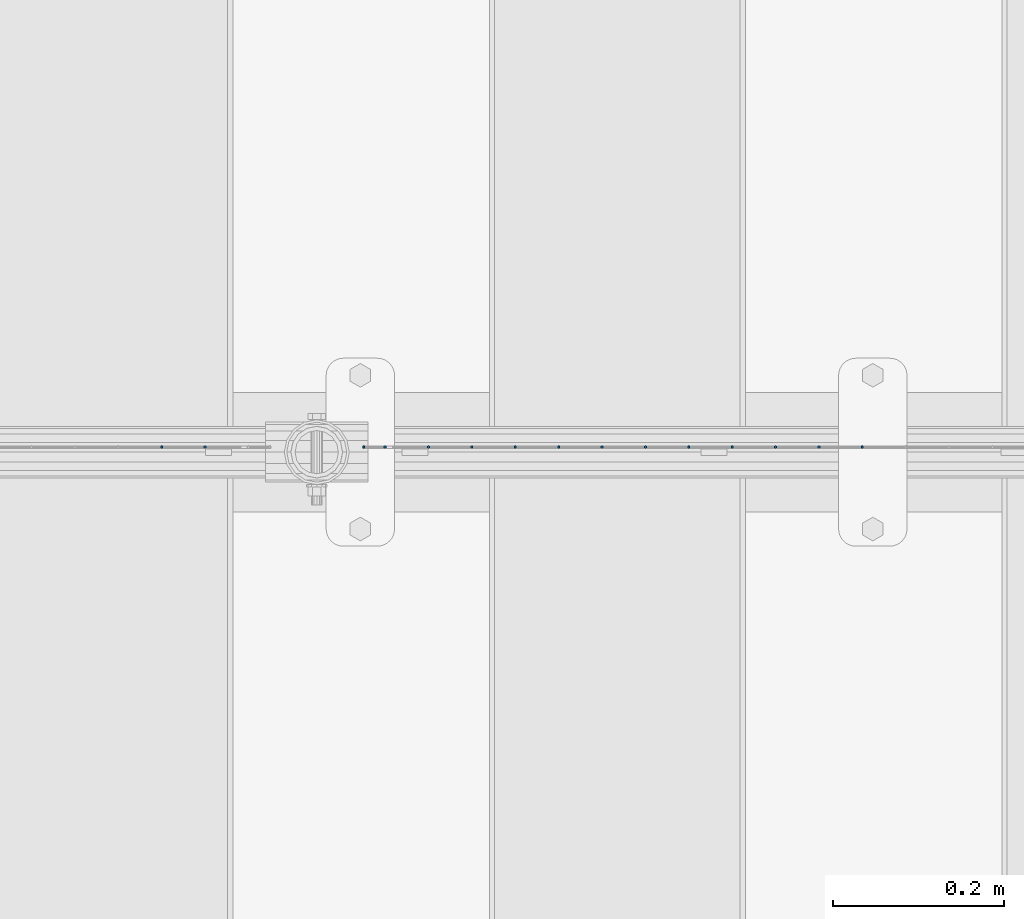
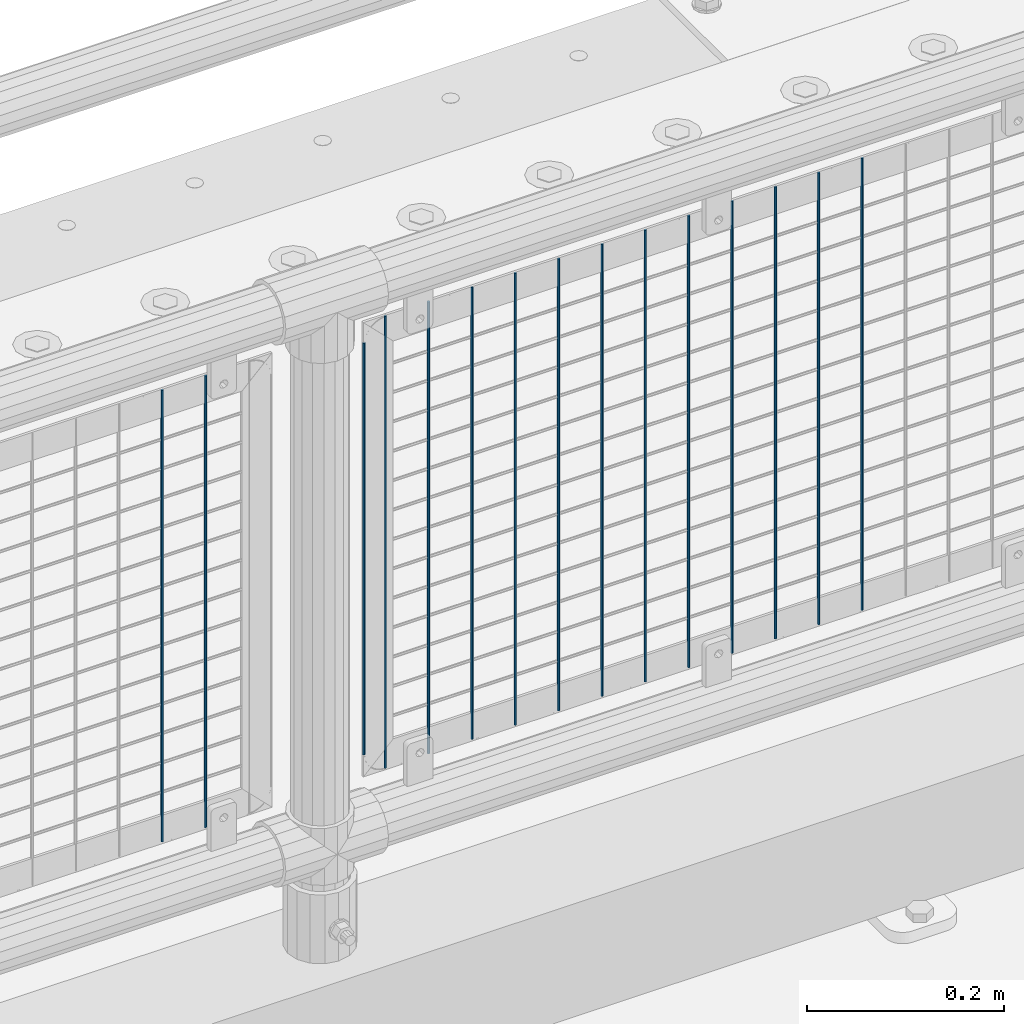
# One storey, part 97 of 242: 15 columns.
"""IFC2X3 building model written with IfcOpenShell, lengths in millimetres."""

from ifc_helpers import new_model, si_unit, frame, origin_with_axes, place, context, subcontext, project, spatial, faceted_brep, material, type_object, element, save


model = new_model("IFC2X3")

# Units and contexts
model_context = context("Model", 3, precision=1e-05, world=origin_with_axes())
body_context = subcontext(model_context, "Body", "Model", "MODEL_VIEW")
ifc_project = project(units=[si_unit("LENGTHUNIT", "METRE", prefix="MILLI"), si_unit("AREAUNIT", "SQUARE_METRE"), si_unit("VOLUMEUNIT", "CUBIC_METRE"), si_unit("MASSUNIT", "GRAM", prefix="KILO"), si_unit("TIMEUNIT", "SECOND"), si_unit("PLANEANGLEUNIT", "RADIAN"), si_unit("SOLIDANGLEUNIT", "STERADIAN"), si_unit("THERMODYNAMICTEMPERATUREUNIT", "DEGREE_CELSIUS"), si_unit("LUMINOUSINTENSITYUNIT", "LUMEN")], contexts=[model_context])

# Site, building, storey
site_placement = place(None, origin_with_axes())
site = spatial("IfcSite", under=ifc_project, at=site_placement, CompositionType="ELEMENT")
building_placement = place(site_placement, origin_with_axes())
building = spatial("IfcBuilding", under=site, at=building_placement, Name="Standard", CompositionType="ELEMENT")
storey_placement = place(building_placement, origin_with_axes())
storey = spatial("IfcBuildingStorey", under=building, at=storey_placement, Name="Undefined", CompositionType="ELEMENT", Elevation=0.0)

# Columns
ifc_material = material(Name="Misc_Undefined")
column_type = type_object("IfcColumnType", Name="D3", PredefinedType="NOTDEFINED")
for number, where, z_axis, x_axis in (
    (1, (-26493.277, -19329.5, 353.02), (-1.0, 0.0, 0.0), (0.0, 0.0, 1.0)),
    (2, (-26544.07, -19329.5, 353.02), (-1.0, 0.0, 0.0), (0.0, 0.0, 1.0)),
    (3, (-26594.863, -19329.5, 353.02), (-1.0, 0.0, 0.0), (0.0, 0.0, 1.0)),
    (4, (-26645.656, -19329.5, 353.02), (-1.0, 0.0, 0.0), (0.0, 0.0, 1.0)),
    (5, (-26696.449, -19329.5, 353.02), (-1.0, 0.0, 0.0), (0.0, 0.0, 1.0)),
    (6, (-26747.242, -19329.5, 353.02), (-1.0, 0.0, 0.0), (0.0, 0.0, 1.0)),
    (7, (-26798.035, -19329.5, 353.02), (-1.0, 0.0, 0.0), (0.0, 0.0, 1.0)),
    (8, (-26848.828, -19329.5, 353.02), (-1.0, 0.0, 0.0), (0.0, 0.0, 1.0)),
    (9, (-26899.621, -19329.5, 353.02), (-1.0, 0.0, 0.0), (0.0, 0.0, 1.0)),
    (10, (-26950.414, -19329.5, 353.02), (-1.0, 0.0, 0.0), (0.0, 0.0, 1.0)),
    (11, (-27001.207, -19329.5, 353.02), (-1.0, 0.0, 0.0), (0.0, 0.0, 1.0)),
):
    element("IfcColumn", number, at=place(storey_placement, frame(where, z_axis=z_axis, x_axis=x_axis)), inside=storey, type_object=column_type, material=ifc_material, ObjectType="D3", context=body_context, shape_type="Brep", body=[
        faceted_brep([(0.0, -1.50000000000364, 0.0), (-3.63797880709171e-12, -0.750000000003638, -1.29903810567669), (560.0, -0.75, -1.29903810567703), (560.0, -1.5, 0.0), (0.0, 0.749999999996362, -1.29903810567669), (560.0, 0.75, -1.29903810567703), (-3.63797880709171e-12, 1.49999999999636, 0.0), (560.0, 1.5, 0.0), (0.0, 0.749999999996362, 1.29903810567669), (560.0, 0.75, 1.29903810567703), (-3.63797880709171e-12, -0.750000000003638, 1.29903810567669), (560.0, -0.75, 1.29903810567703)], [[[0, 1, 2, 3]], [[1, 4, 5, 2]], [[4, 6, 7, 5]], [[6, 8, 9, 7]], [[8, 10, 11, 9]], [[10, 0, 3, 11]], [[5, 7, 9, 11, 3, 2]], [[10, 8, 6, 4, 1, 0]]]),
    ])
column_placement = place(storey_placement, frame((-27077.0, -19329.5, 378.02), z_axis=(-1.0, 0.0, 0.0), x_axis=(0.0, 0.0, 1.0)))
element("IfcColumn", 12, at=column_placement, inside=storey, type_object=column_type, material=ifc_material, ObjectType="D3", context=body_context, shape_type="Brep", body=[
    faceted_brep([(0.0, -1.50000000000364, 0.0), (-3.63797880709171e-12, -0.750000000003638, -1.29903810567669), (510.0, -0.75, -1.29903810567703), (510.0, -1.5, 0.0), (0.0, 0.749999999996362, -1.29903810567669), (510.0, 0.75, -1.29903810567703), (-3.63797880709171e-12, 1.49999999999636, 0.0), (510.0, 1.5, 0.0), (0.0, 0.749999999996362, 1.29903810567669), (510.0, 0.75, 1.29903810567703), (-3.63797880709171e-12, -0.750000000003638, 1.29903810567669), (510.0, -0.75, 1.29903810567703)], [[[0, 1, 2, 3]], [[1, 4, 5, 2]], [[4, 6, 7, 5]], [[6, 8, 9, 7]], [[8, 10, 11, 9]], [[10, 0, 3, 11]], [[5, 7, 9, 11, 3, 2]], [[10, 8, 6, 4, 1, 0]]]),
])
for number, where, z_axis, x_axis in (
    (13, (-27052.0, -19329.5, 353.02), (-1.0, 0.0, 0.0), (0.0, 0.0, 1.0)),
    (14, (-27262.796, -19329.5, 353.02), (-1.0, 0.0, 0.0), (0.0, 0.0, 1.0)),
    (15, (-27313.589, -19329.5, 353.02), (-1.0, 0.0, 0.0), (0.0, 0.0, 1.0)),
):
    element("IfcColumn", number, at=place(storey_placement, frame(where, z_axis=z_axis, x_axis=x_axis)), inside=storey, type_object=column_type, material=ifc_material, ObjectType="D3", context=body_context, shape_type="Brep", body=[
        faceted_brep([(0.0, -1.50000000000364, 0.0), (-3.63797880709171e-12, -0.750000000003638, -1.29903810567669), (560.0, -0.75, -1.29903810567703), (560.0, -1.5, 0.0), (0.0, 0.749999999996362, -1.29903810567669), (560.0, 0.75, -1.29903810567703), (-3.63797880709171e-12, 1.49999999999636, 0.0), (560.0, 1.5, 0.0), (0.0, 0.749999999996362, 1.29903810567669), (560.0, 0.75, 1.29903810567703), (-3.63797880709171e-12, -0.750000000003638, 1.29903810567669), (560.0, -0.75, 1.29903810567703)], [[[0, 1, 2, 3]], [[1, 4, 5, 2]], [[4, 6, 7, 5]], [[6, 8, 9, 7]], [[8, 10, 11, 9]], [[10, 0, 3, 11]], [[5, 7, 9, 11, 3, 2]], [[10, 8, 6, 4, 1, 0]]]),
    ])

save(model, "model.ifc")
